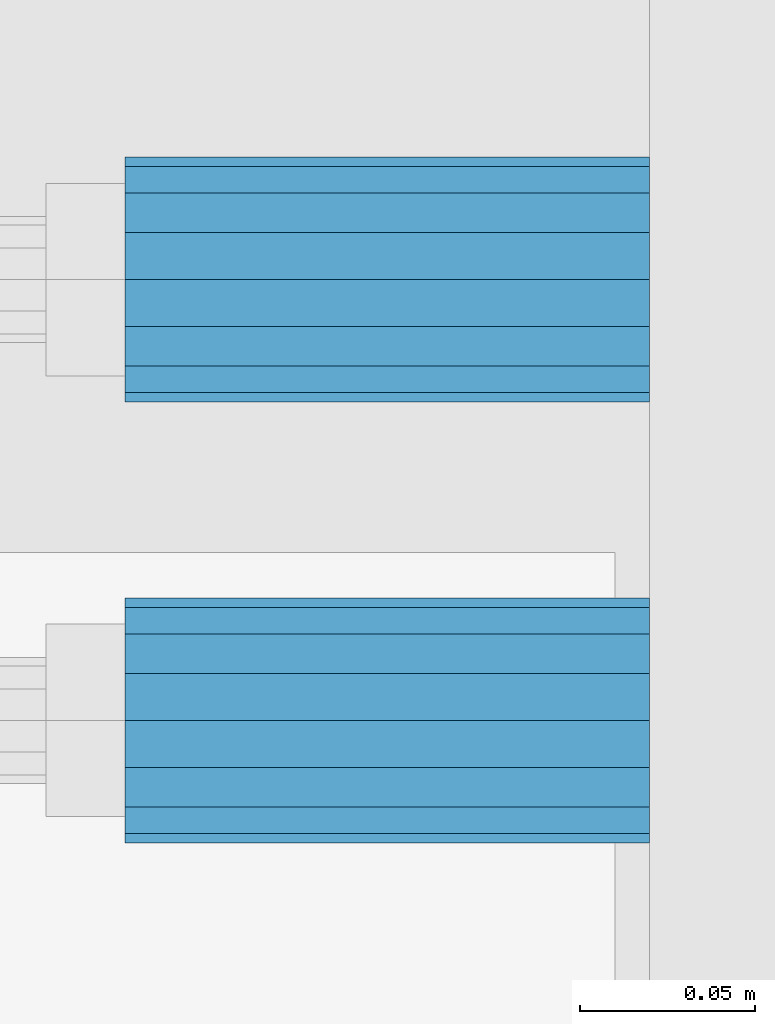
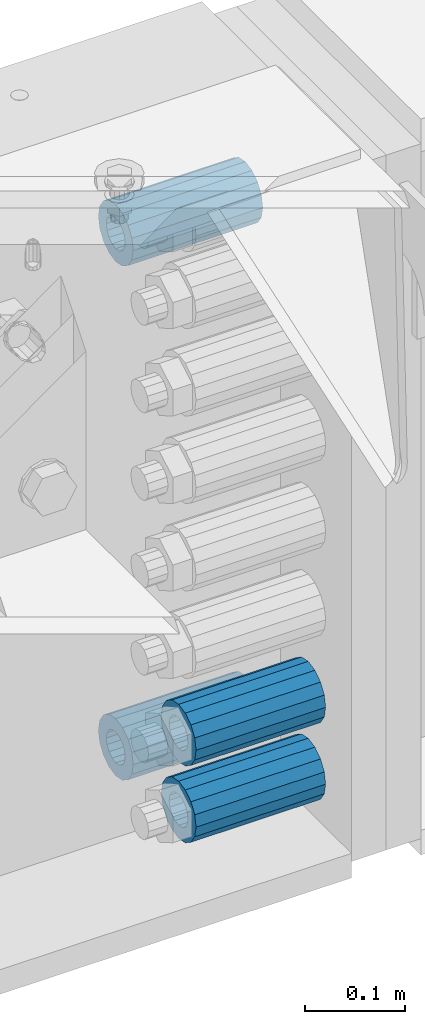
# One storey, part 176 of 247: 4 beams.
"""IFC2X3 building model written with IfcOpenShell, lengths in millimetres."""

from ifc_helpers import new_model, si_unit, frame, origin_with_axes, place, context, subcontext, project, spatial, faceted_brep, material, type_object, element, save


model = new_model("IFC2X3")

# Units and contexts
model_context = context("Model", 3, precision=1e-05, world=origin_with_axes())
body_context = subcontext(model_context, "Body", "Model", "MODEL_VIEW")
ifc_project = project(units=[si_unit("LENGTHUNIT", "METRE", prefix="MILLI"), si_unit("AREAUNIT", "SQUARE_METRE"), si_unit("VOLUMEUNIT", "CUBIC_METRE"), si_unit("MASSUNIT", "GRAM", prefix="KILO"), si_unit("TIMEUNIT", "SECOND"), si_unit("PLANEANGLEUNIT", "RADIAN"), si_unit("SOLIDANGLEUNIT", "STERADIAN"), si_unit("THERMODYNAMICTEMPERATUREUNIT", "DEGREE_CELSIUS"), si_unit("LUMINOUSINTENSITYUNIT", "LUMEN")], contexts=[model_context])

# Site, building, storey
site_placement = place(None, origin_with_axes())
site = spatial("IfcSite", under=ifc_project, at=site_placement, CompositionType="ELEMENT")
building_placement = place(site_placement, origin_with_axes())
building = spatial("IfcBuilding", under=site, at=building_placement, Name="Standard", CompositionType="ELEMENT")
storey_placement = place(building_placement, origin_with_axes())
storey = spatial("IfcBuildingStorey", under=building, at=storey_placement, Name="Undefined", CompositionType="ELEMENT", Elevation=0.0)

# Beams
ifc_material = material()
beam_type = type_object("IfcBeamType", PredefinedType="NOTDEFINED")
beam_1_placement = place(storey_placement, frame((16667.0, 9063.0, -178.0), z_axis=(0.0, 0.0, 1.0), x_axis=(1.0, 0.0, 0.0)))
element("IfcBeam", 1, at=beam_1_placement, inside=storey, type_object=beam_type, material=ifc_material, context=body_context, shape_type="Brep", body=[
    faceted_brep([(-1.3120632047503e-07, -18.9999999995497, -6.27005647402257e-09), (0.0, -17.5537111177146, 7.27098521493672), (150.0, -17.5537111177146, 7.27098521493672), (150.0, -19.0, 0.0), (0.0, -13.4350288425444, 13.4350288425444), (150.0, -13.4350288425444, 13.4350288425444), (0.0, -7.2709852149369, 17.5537111177144), (150.0, -7.2709852149369, 17.5537111177144), (-6.3396328187082e-09, 4.50427251053043e-10, 18.9999999937299), (150.0, 0.0, 19.0), (0.0, 7.2709852149369, 17.5537111177144), (150.0, 7.2709852149369, 17.5537111177144), (0.0, 13.4350288425444, 13.4350288425444), (150.0, 13.4350288425444, 13.4350288425444), (0.0, 17.5537111177146, 7.2709852149367), (150.0, 17.5537111177146, 7.2709852149367), (1.33208573060983e-07, 19.0000000004504, -6.27005647402257e-09), (150.0, 19.0, 0.0), (0.0, 17.5537111177146, -7.2709852149367), (150.0, 17.5537111177146, -7.2709852149367), (0.0, 13.4350288425444, -13.4350288425444), (150.0, 13.4350288425444, -13.4350288425444), (0.0, 7.2709852149369, -17.5537111177144), (150.0, 7.2709852149369, -17.5537111177144), (8.3418854046613e-09, 4.50427251053043e-10, -19.0000000062682), (150.0, 0.0, -19.0), (0.0, -7.2709852149369, -17.5537111177144), (150.0, -7.2709852149369, -17.5537111177144), (0.0, -13.4350288425444, -13.4350288425444), (150.0, -13.4350288425444, -13.4350288425444), (0.0, -17.5537111177146, -7.2709852149367), (150.0, -17.5537111177146, -7.2709852149367), (0.0, -35.0, 0.0), (0.0, -32.335783637895, -13.3939201327782), (150.0, -32.335783637895, -13.3939201327782), (150.0, -35.0, 0.0), (0.0, -24.7487373415292, -24.7487373415291), (150.0, -24.7487373415293, -24.7487373415292), (0.0, -13.3939201327781, -32.335783637895), (150.0, -13.393920132778, -32.335783637895), (0.0, 0.0, -35.0000000000001), (150.0, 0.0, -35.0), (0.0, 13.3939201327782, -32.335783637895), (150.0, 13.393920132778, -32.335783637895), (0.0, 24.7487373415292, -24.7487373415291), (150.0, 24.7487373415293, -24.7487373415292), (0.0, 32.335783637895, -13.3939201327782), (150.0, 32.335783637895, -13.3939201327781), (0.0, 35.0, 0.0), (150.0, 35.0, 0.0), (0.0, 32.335783637895, 13.3939201327781), (150.0, 32.335783637895, 13.3939201327781), (0.0, 24.7487373415292, 24.748737341529), (150.0, 24.7487373415293, 24.7487373415292), (0.0, 13.3939201327781, 32.335783637895), (150.0, 13.393920132778, 32.335783637895), (0.0, 0.0, 35.0), (150.0, 0.0, 35.0), (0.0, -13.3939201327781, 32.335783637895), (150.0, -13.393920132778, 32.335783637895), (0.0, -24.7487373415292, 24.748737341529), (150.0, -24.7487373415293, 24.7487373415292), (0.0, -32.335783637895, 13.3939201327781), (150.0, -32.335783637895, 13.3939201327781)], [[[0, 1, 2, 3]], [[1, 4, 5, 2]], [[4, 6, 7, 5]], [[6, 8, 9, 7]], [[8, 10, 11, 9]], [[10, 12, 13, 11]], [[12, 14, 15, 13]], [[14, 16, 17, 15]], [[16, 18, 19, 17]], [[18, 20, 21, 19]], [[20, 22, 23, 21]], [[22, 24, 25, 23]], [[24, 26, 27, 25]], [[26, 28, 29, 27]], [[28, 30, 31, 29]], [[30, 0, 3, 31]], [[32, 33, 34, 35]], [[33, 36, 37, 34]], [[36, 38, 39, 37]], [[38, 40, 41, 39]], [[40, 42, 43, 41]], [[42, 44, 45, 43]], [[44, 46, 47, 45]], [[46, 48, 49, 47]], [[48, 50, 51, 49]], [[50, 52, 53, 51]], [[52, 54, 55, 53]], [[54, 56, 57, 55]], [[56, 58, 59, 57]], [[58, 60, 61, 59]], [[60, 62, 63, 61]], [[62, 32, 35, 63]], [[37, 39, 41, 43, 45, 47, 49, 51, 53, 55, 57, 59, 61, 63, 35, 34], [5, 7, 9, 11, 13, 15, 17, 19, 21, 23, 25, 27, 29, 31, 3, 2]], [[62, 60, 58, 56, 54, 52, 50, 48, 46, 44, 42, 40, 38, 36, 33, 32], [30, 28, 26, 24, 22, 20, 18, 16, 14, 12, 10, 8, 6, 4, 1, 0]]]),
])
beam_2_placement = place(storey_placement, frame((16667.0, 8937.0, -713.0), z_axis=(0.0, 0.0, 1.0), x_axis=(1.0, 0.0, 0.0)))
element("IfcBeam", 2, at=beam_2_placement, inside=storey, type_object=beam_type, material=ifc_material, context=body_context, shape_type="Brep", body=[
    faceted_brep([(-1.3120632047503e-07, -18.9999999995497, -6.27005647402257e-09), (0.0, -17.5537111177146, 7.27098521493672), (150.0, -17.5537111177146, 7.27098521493672), (150.0, -19.0, 0.0), (0.0, -13.4350288425444, 13.4350288425444), (150.0, -13.4350288425444, 13.4350288425444), (0.0, -7.2709852149369, 17.5537111177144), (150.0, -7.2709852149369, 17.5537111177144), (-6.3396328187082e-09, 4.50427251053043e-10, 18.9999999937299), (150.0, 0.0, 19.0), (0.0, 7.2709852149369, 17.5537111177144), (150.0, 7.2709852149369, 17.5537111177144), (0.0, 13.4350288425444, 13.4350288425444), (150.0, 13.4350288425444, 13.4350288425444), (0.0, 17.5537111177146, 7.2709852149367), (150.0, 17.5537111177146, 7.2709852149367), (1.33208573060983e-07, 19.0000000004504, -6.27005647402257e-09), (150.0, 19.0, 0.0), (0.0, 17.5537111177146, -7.2709852149367), (150.0, 17.5537111177146, -7.2709852149367), (0.0, 13.4350288425444, -13.4350288425444), (150.0, 13.4350288425444, -13.4350288425444), (0.0, 7.2709852149369, -17.5537111177144), (150.0, 7.2709852149369, -17.5537111177144), (8.3418854046613e-09, 4.50427251053043e-10, -19.0000000062682), (150.0, 0.0, -19.0), (0.0, -7.2709852149369, -17.5537111177144), (150.0, -7.2709852149369, -17.5537111177144), (0.0, -13.4350288425444, -13.4350288425444), (150.0, -13.4350288425444, -13.4350288425444), (0.0, -17.5537111177146, -7.2709852149367), (150.0, -17.5537111177146, -7.2709852149367), (0.0, -35.0, 0.0), (0.0, -32.335783637895, -13.3939201327782), (150.0, -32.335783637895, -13.3939201327782), (150.0, -35.0, 0.0), (0.0, -24.7487373415292, -24.7487373415291), (150.0, -24.7487373415293, -24.7487373415292), (0.0, -13.3939201327781, -32.335783637895), (150.0, -13.393920132778, -32.335783637895), (0.0, 0.0, -35.0000000000001), (150.0, 0.0, -35.0), (0.0, 13.3939201327782, -32.335783637895), (150.0, 13.393920132778, -32.335783637895), (0.0, 24.7487373415292, -24.7487373415291), (150.0, 24.7487373415293, -24.7487373415292), (0.0, 32.335783637895, -13.3939201327782), (150.0, 32.335783637895, -13.3939201327781), (0.0, 35.0, 0.0), (150.0, 35.0, 0.0), (0.0, 32.335783637895, 13.3939201327781), (150.0, 32.335783637895, 13.3939201327781), (0.0, 24.7487373415292, 24.748737341529), (150.0, 24.7487373415293, 24.7487373415292), (0.0, 13.3939201327781, 32.335783637895), (150.0, 13.393920132778, 32.335783637895), (0.0, 0.0, 35.0), (150.0, 0.0, 35.0), (0.0, -13.3939201327781, 32.335783637895), (150.0, -13.393920132778, 32.335783637895), (0.0, -24.7487373415292, 24.748737341529), (150.0, -24.7487373415293, 24.7487373415292), (0.0, -32.335783637895, 13.3939201327781), (150.0, -32.335783637895, 13.3939201327781)], [[[0, 1, 2, 3]], [[1, 4, 5, 2]], [[4, 6, 7, 5]], [[6, 8, 9, 7]], [[8, 10, 11, 9]], [[10, 12, 13, 11]], [[12, 14, 15, 13]], [[14, 16, 17, 15]], [[16, 18, 19, 17]], [[18, 20, 21, 19]], [[20, 22, 23, 21]], [[22, 24, 25, 23]], [[24, 26, 27, 25]], [[26, 28, 29, 27]], [[28, 30, 31, 29]], [[30, 0, 3, 31]], [[32, 33, 34, 35]], [[33, 36, 37, 34]], [[36, 38, 39, 37]], [[38, 40, 41, 39]], [[40, 42, 43, 41]], [[42, 44, 45, 43]], [[44, 46, 47, 45]], [[46, 48, 49, 47]], [[48, 50, 51, 49]], [[50, 52, 53, 51]], [[52, 54, 55, 53]], [[54, 56, 57, 55]], [[56, 58, 59, 57]], [[58, 60, 61, 59]], [[60, 62, 63, 61]], [[62, 32, 35, 63]], [[37, 39, 41, 43, 45, 47, 49, 51, 53, 55, 57, 59, 61, 63, 35, 34], [5, 7, 9, 11, 13, 15, 17, 19, 21, 23, 25, 27, 29, 31, 3, 2]], [[62, 60, 58, 56, 54, 52, 50, 48, 46, 44, 42, 40, 38, 36, 33, 32], [30, 28, 26, 24, 22, 20, 18, 16, 14, 12, 10, 8, 6, 4, 1, 0]]]),
])
beam_3_placement = place(storey_placement, frame((16667.0, 9063.0, -807.0), z_axis=(0.0, 0.0, 1.0), x_axis=(1.0, 0.0, 0.0)))
element("IfcBeam", 3, at=beam_3_placement, inside=storey, type_object=beam_type, material=ifc_material, context=body_context, shape_type="Brep", body=[
    faceted_brep([(-1.3120632047503e-07, -18.9999999995497, -6.27005647402257e-09), (0.0, -17.5537111177146, 7.27098521493672), (150.0, -17.5537111177146, 7.27098521493672), (150.0, -19.0, 0.0), (0.0, -13.4350288425444, 13.4350288425444), (150.0, -13.4350288425444, 13.4350288425444), (0.0, -7.2709852149369, 17.5537111177144), (150.0, -7.2709852149369, 17.5537111177144), (-6.3396328187082e-09, 4.50427251053043e-10, 18.9999999937299), (150.0, 0.0, 19.0), (0.0, 7.2709852149369, 17.5537111177144), (150.0, 7.2709852149369, 17.5537111177144), (0.0, 13.4350288425444, 13.4350288425444), (150.0, 13.4350288425444, 13.4350288425444), (0.0, 17.5537111177146, 7.2709852149367), (150.0, 17.5537111177146, 7.2709852149367), (1.33208573060983e-07, 19.0000000004504, -6.27005647402257e-09), (150.0, 19.0, 0.0), (0.0, 17.5537111177146, -7.2709852149367), (150.0, 17.5537111177146, -7.2709852149367), (0.0, 13.4350288425444, -13.4350288425444), (150.0, 13.4350288425444, -13.4350288425444), (0.0, 7.2709852149369, -17.5537111177144), (150.0, 7.2709852149369, -17.5537111177144), (8.3418854046613e-09, 4.50427251053043e-10, -19.0000000062682), (150.0, 0.0, -19.0), (0.0, -7.2709852149369, -17.5537111177144), (150.0, -7.2709852149369, -17.5537111177144), (0.0, -13.4350288425444, -13.4350288425444), (150.0, -13.4350288425444, -13.4350288425444), (0.0, -17.5537111177146, -7.2709852149367), (150.0, -17.5537111177146, -7.2709852149367), (0.0, -35.0, 0.0), (0.0, -32.335783637895, -13.3939201327782), (150.0, -32.335783637895, -13.3939201327782), (150.0, -35.0, 0.0), (0.0, -24.7487373415292, -24.7487373415291), (150.0, -24.7487373415293, -24.7487373415292), (0.0, -13.3939201327781, -32.335783637895), (150.0, -13.393920132778, -32.335783637895), (0.0, 0.0, -35.0000000000001), (150.0, 0.0, -35.0), (0.0, 13.3939201327782, -32.335783637895), (150.0, 13.393920132778, -32.335783637895), (0.0, 24.7487373415292, -24.7487373415291), (150.0, 24.7487373415293, -24.7487373415292), (0.0, 32.335783637895, -13.3939201327782), (150.0, 32.335783637895, -13.3939201327781), (0.0, 35.0, 0.0), (150.0, 35.0, 0.0), (0.0, 32.335783637895, 13.3939201327781), (150.0, 32.335783637895, 13.3939201327781), (0.0, 24.7487373415292, 24.748737341529), (150.0, 24.7487373415293, 24.7487373415292), (0.0, 13.3939201327781, 32.335783637895), (150.0, 13.393920132778, 32.335783637895), (0.0, 0.0, 35.0), (150.0, 0.0, 35.0), (0.0, -13.3939201327781, 32.335783637895), (150.0, -13.393920132778, 32.335783637895), (0.0, -24.7487373415292, 24.748737341529), (150.0, -24.7487373415293, 24.7487373415292), (0.0, -32.335783637895, 13.3939201327781), (150.0, -32.335783637895, 13.3939201327781)], [[[0, 1, 2, 3]], [[1, 4, 5, 2]], [[4, 6, 7, 5]], [[6, 8, 9, 7]], [[8, 10, 11, 9]], [[10, 12, 13, 11]], [[12, 14, 15, 13]], [[14, 16, 17, 15]], [[16, 18, 19, 17]], [[18, 20, 21, 19]], [[20, 22, 23, 21]], [[22, 24, 25, 23]], [[24, 26, 27, 25]], [[26, 28, 29, 27]], [[28, 30, 31, 29]], [[30, 0, 3, 31]], [[32, 33, 34, 35]], [[33, 36, 37, 34]], [[36, 38, 39, 37]], [[38, 40, 41, 39]], [[40, 42, 43, 41]], [[42, 44, 45, 43]], [[44, 46, 47, 45]], [[46, 48, 49, 47]], [[48, 50, 51, 49]], [[50, 52, 53, 51]], [[52, 54, 55, 53]], [[54, 56, 57, 55]], [[56, 58, 59, 57]], [[58, 60, 61, 59]], [[60, 62, 63, 61]], [[62, 32, 35, 63]], [[37, 39, 41, 43, 45, 47, 49, 51, 53, 55, 57, 59, 61, 63, 35, 34], [5, 7, 9, 11, 13, 15, 17, 19, 21, 23, 25, 27, 29, 31, 3, 2]], [[62, 60, 58, 56, 54, 52, 50, 48, 46, 44, 42, 40, 38, 36, 33, 32], [30, 28, 26, 24, 22, 20, 18, 16, 14, 12, 10, 8, 6, 4, 1, 0]]]),
])
beam_4_placement = place(storey_placement, frame((16667.0, 8937.0, -807.0), z_axis=(0.0, 0.0, 1.0), x_axis=(1.0, 0.0, 0.0)))
element("IfcBeam", 4, at=beam_4_placement, inside=storey, type_object=beam_type, material=ifc_material, context=body_context, shape_type="Brep", body=[
    faceted_brep([(-1.3120632047503e-07, -18.9999999995497, -6.27005647402257e-09), (0.0, -17.5537111177146, 7.27098521493672), (150.0, -17.5537111177146, 7.27098521493672), (150.0, -19.0, 0.0), (0.0, -13.4350288425444, 13.4350288425444), (150.0, -13.4350288425444, 13.4350288425444), (0.0, -7.2709852149369, 17.5537111177144), (150.0, -7.2709852149369, 17.5537111177144), (-6.3396328187082e-09, 4.50427251053043e-10, 18.9999999937299), (150.0, 0.0, 19.0), (0.0, 7.2709852149369, 17.5537111177144), (150.0, 7.2709852149369, 17.5537111177144), (0.0, 13.4350288425444, 13.4350288425444), (150.0, 13.4350288425444, 13.4350288425444), (0.0, 17.5537111177146, 7.2709852149367), (150.0, 17.5537111177146, 7.2709852149367), (1.33208573060983e-07, 19.0000000004504, -6.27005647402257e-09), (150.0, 19.0, 0.0), (0.0, 17.5537111177146, -7.2709852149367), (150.0, 17.5537111177146, -7.2709852149367), (0.0, 13.4350288425444, -13.4350288425444), (150.0, 13.4350288425444, -13.4350288425444), (0.0, 7.2709852149369, -17.5537111177144), (150.0, 7.2709852149369, -17.5537111177144), (8.3418854046613e-09, 4.50427251053043e-10, -19.0000000062682), (150.0, 0.0, -19.0), (0.0, -7.2709852149369, -17.5537111177144), (150.0, -7.2709852149369, -17.5537111177144), (0.0, -13.4350288425444, -13.4350288425444), (150.0, -13.4350288425444, -13.4350288425444), (0.0, -17.5537111177146, -7.2709852149367), (150.0, -17.5537111177146, -7.2709852149367), (0.0, -35.0, 0.0), (0.0, -32.335783637895, -13.3939201327782), (150.0, -32.335783637895, -13.3939201327782), (150.0, -35.0, 0.0), (0.0, -24.7487373415292, -24.7487373415291), (150.0, -24.7487373415293, -24.7487373415292), (0.0, -13.3939201327781, -32.335783637895), (150.0, -13.393920132778, -32.335783637895), (0.0, 0.0, -35.0000000000001), (150.0, 0.0, -35.0), (0.0, 13.3939201327782, -32.335783637895), (150.0, 13.393920132778, -32.335783637895), (0.0, 24.7487373415292, -24.7487373415291), (150.0, 24.7487373415293, -24.7487373415292), (0.0, 32.335783637895, -13.3939201327782), (150.0, 32.335783637895, -13.3939201327781), (0.0, 35.0, 0.0), (150.0, 35.0, 0.0), (0.0, 32.335783637895, 13.3939201327781), (150.0, 32.335783637895, 13.3939201327781), (0.0, 24.7487373415292, 24.748737341529), (150.0, 24.7487373415293, 24.7487373415292), (0.0, 13.3939201327781, 32.335783637895), (150.0, 13.393920132778, 32.335783637895), (0.0, 0.0, 35.0), (150.0, 0.0, 35.0), (0.0, -13.3939201327781, 32.335783637895), (150.0, -13.393920132778, 32.335783637895), (0.0, -24.7487373415292, 24.748737341529), (150.0, -24.7487373415293, 24.7487373415292), (0.0, -32.335783637895, 13.3939201327781), (150.0, -32.335783637895, 13.3939201327781)], [[[0, 1, 2, 3]], [[1, 4, 5, 2]], [[4, 6, 7, 5]], [[6, 8, 9, 7]], [[8, 10, 11, 9]], [[10, 12, 13, 11]], [[12, 14, 15, 13]], [[14, 16, 17, 15]], [[16, 18, 19, 17]], [[18, 20, 21, 19]], [[20, 22, 23, 21]], [[22, 24, 25, 23]], [[24, 26, 27, 25]], [[26, 28, 29, 27]], [[28, 30, 31, 29]], [[30, 0, 3, 31]], [[32, 33, 34, 35]], [[33, 36, 37, 34]], [[36, 38, 39, 37]], [[38, 40, 41, 39]], [[40, 42, 43, 41]], [[42, 44, 45, 43]], [[44, 46, 47, 45]], [[46, 48, 49, 47]], [[48, 50, 51, 49]], [[50, 52, 53, 51]], [[52, 54, 55, 53]], [[54, 56, 57, 55]], [[56, 58, 59, 57]], [[58, 60, 61, 59]], [[60, 62, 63, 61]], [[62, 32, 35, 63]], [[37, 39, 41, 43, 45, 47, 49, 51, 53, 55, 57, 59, 61, 63, 35, 34], [5, 7, 9, 11, 13, 15, 17, 19, 21, 23, 25, 27, 29, 31, 3, 2]], [[62, 60, 58, 56, 54, 52, 50, 48, 46, 44, 42, 40, 38, 36, 33, 32], [30, 28, 26, 24, 22, 20, 18, 16, 14, 12, 10, 8, 6, 4, 1, 0]]]),
])

save(model, "model.ifc")
